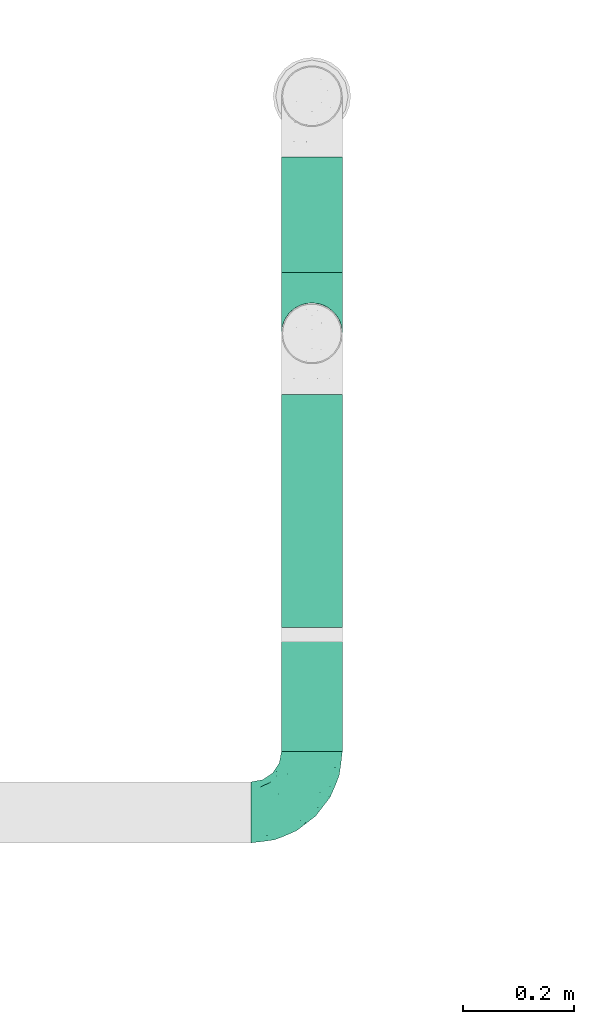
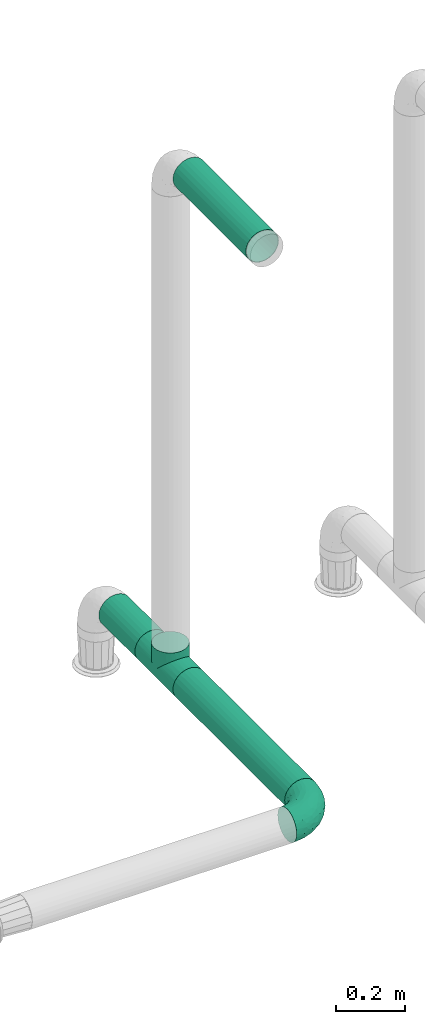
# One storey, part 23 of 103: 3 flow segments, 2 flow fittings.
"""IFC2X3 building model written with IfcOpenShell, lengths in millimetres."""

from ifc_helpers import new_model, entity, si_unit, converted_unit, derived_unit, direction, frame, origin_with_axes, origin_2d_with_axis, place, context, subcontext, project, spatial, hollow_circle, extrude, open_shell, surface_model, source, transform, mapped, material, layer, layer_set, layer_usage, type_object, element, save


model = new_model("IFC2X3")

# Units and contexts
model_context = context("Model", 3, precision=1e-05, world=origin_with_axes(), true_north=direction((0.0, 1.0)))
body_context = subcontext(model_context, "Body", "Model", "MODEL_VIEW")
ifc_project = project(units=[si_unit("AREAUNIT", "SQUARE_METRE"), si_unit("VOLUMEUNIT", "CUBIC_METRE", prefix="DECI"), si_unit("TIMEUNIT", "SECOND"), si_unit("THERMODYNAMICTEMPERATUREUNIT", "DEGREE_CELSIUS"), si_unit("PRESSUREUNIT", "PASCAL"), si_unit("MASSUNIT", "GRAM", prefix="KILO"), si_unit("LENGTHUNIT", "METRE", prefix="MILLI"), si_unit("POWERUNIT", "WATT"), si_unit("ELECTRICCURRENTUNIT", "AMPERE"), si_unit("ELECTRICVOLTAGEUNIT", "VOLT"), derived_unit("VOLUMETRICFLOWRATEUNIT", [(si_unit("VOLUMEUNIT", "CUBIC_METRE", prefix="DECI"), 1), (si_unit("TIMEUNIT", "SECOND"), -1)]), derived_unit("LINEARVELOCITYUNIT", [(si_unit("LENGTHUNIT", "METRE"), 1), (si_unit("TIMEUNIT", "SECOND"), -1)]), derived_unit("MASSDENSITYUNIT", [(si_unit("MASSUNIT", "GRAM", prefix="KILO"), 1), (si_unit("VOLUMEUNIT", "CUBIC_METRE"), -1)]), converted_unit("PLANEANGLEUNIT", "DEGREE", entity("IfcRatioMeasure", 0.01745), si_unit("PLANEANGLEUNIT", "RADIAN"), dimensions=[0, 0, 0, 0, 0, 0, 0])], contexts=[model_context])

# Site, building, storey
site_placement = place(None, origin_with_axes())
site = spatial("IfcSite", under=ifc_project, at=site_placement, CompositionType="ELEMENT")
building_placement = place(site_placement, origin_with_axes())
building = spatial("IfcBuilding", under=site, at=building_placement, Name="mc-building", CompositionType="ELEMENT")
storey_placement = place(building_placement, frame((0.0, 0.0, 5900.0), z_axis=(0.0, 0.0, 1.0), x_axis=(1.0, 0.0, 0.0)))
storey = spatial("IfcBuildingStorey", under=building, at=storey_placement, Name="3. Korrus", CompositionType="ELEMENT", Elevation=5900.0)

# Flow fittings
duct_fitting_type_1 = type_object("IfcDuctFittingType", PredefinedType="JUNCTION")
shared_shape_1 = source(origin_with_axes(), body_context, "Body", "SurfaceModel", [
    surface_model("IfcShellBasedSurfaceModel", [(0.0, -80.0, -55.0), (14.23505, -80.0, -53.12592), (-14.23505, -80.0, -53.12592), (-53.12592, -80.0, 14.23505), (-27.5, -80.0, -47.63139), (-47.63139, -80.0, -27.5), (-38.89087, -80.0, -38.89087), (55.0, -80.0, 0.0), (53.12592, -80.0, 14.23505), (38.89087, -80.0, -38.89087), (27.5, -80.0, -47.63139), (53.12592, -80.0, -14.23505), (47.63139, -80.0, -27.5), (-53.12592, -80.0, -14.23505), (-47.63139, -80.0, 27.5), (-38.89087, -80.0, 38.89087), (14.23505, -80.0, 53.12592), (-27.5, -80.0, 47.63139), (-14.23505, -80.0, 53.12592), (47.63139, -80.0, 27.5), (38.89087, -80.0, 38.89087), (27.5, -80.0, 47.63139), (0.0, -80.0, 55.0), (-55.0, -80.0, 0.0), (0.0, 0.0, 55.0), (-7.4066, -7.4066, 54.49901), (-14.74521, -14.74521, 52.98659), (-21.93978, -21.93978, 50.43457), (-28.89905, -28.89905, 46.79578), (-35.50357, -35.50357, 42.00591), (-41.58668, -41.58668, 35.99373), (-46.92319, -46.92319, 28.69171), (-51.19777, -51.19777, 20.0945), (-50.37866, -80.0, 20.86752), (-54.01174, -54.01174, 10.37938), (-55.0, -55.0, 0.0), (-54.06296, -80.0, 7.11752), (-54.01174, -54.01174, -10.37938), (-51.19777, -51.19777, -20.0945), (-54.06296, -80.0, -7.11752), (-46.92319, -46.92319, -28.69171), (-41.58668, -41.58668, -35.99373), (-50.37866, -80.0, -20.86752), (-35.50357, -35.50357, -42.00591), (-21.93978, -21.93978, -50.43457), (-14.74521, -14.74521, -52.98659), (-7.4066, -7.4066, -54.49901), (0.0, 0.0, -55.0), (-28.89905, -28.89905, -46.79578), (7.4066, -7.4066, -54.49901), (14.74521, -14.74521, -52.98659), (21.93978, -21.93978, -50.43457), (28.89905, -28.89905, -46.79578), (35.50357, -35.50357, -42.00591), (41.58668, -41.58668, -35.99373), (46.92319, -46.92319, -28.69171), (51.19777, -51.19777, -20.0945), (50.37866, -80.0, -20.86752), (54.01174, -54.01174, -10.37938), (55.0, -55.0, 0.0), (54.06296, -80.0, -7.11752), (54.01174, -54.01174, 10.37938), (51.19777, -51.19777, 20.0945), (54.06296, -80.0, 7.11752), (46.92319, -46.92319, 28.69171), (41.58668, -41.58668, 35.99373), (50.37866, -80.0, 20.86752), (35.50357, -35.50357, 42.00591), (21.93978, -21.93978, 50.43457), (14.74521, -14.74521, 52.98659), (7.4066, -7.4066, 54.49901), (28.89905, -28.89905, 46.79578), (-110.0, 0.0, -55.0), (-110.0, -14.23505, -53.12592), (-110.0, 14.23505, -53.12592), (-110.0, 53.12592, 14.23505), (-110.0, 27.5, -47.63139), (-110.0, 47.63139, -27.5), (-110.0, 38.89087, -38.89087), (-110.0, -55.0, 0.0), (-110.0, -53.12592, 14.23505), (-110.0, -38.89087, -38.89087), (-110.0, -27.5, -47.63139), (-110.0, -53.12592, -14.23505), (-110.0, -47.63139, -27.5), (-110.0, 53.12592, -14.23505), (-110.0, 47.63139, 27.5), (-110.0, 38.89087, 38.89087), (-110.0, -14.23505, 53.12592), (-110.0, 27.5, 47.63139), (-110.0, 14.23505, 53.12592), (-110.0, -47.63139, 27.5), (-110.0, -38.89087, 38.89087), (-110.0, -27.5, 47.63139), (-110.0, 0.0, 55.0), (-110.0, 55.0, 0.0), (110.0, 55.0, 0.0), (110.0, 0.0, -55.0), (110.0, 14.23505, -53.12592), (110.0, 27.5, -47.63139), (110.0, 38.89087, -38.89087), (110.0, 47.63139, -27.5), (110.0, -38.89087, -38.89087), (110.0, -53.12592, 14.23505), (110.0, -27.5, -47.63139), (110.0, -14.23505, -53.12592), (110.0, -47.63139, -27.5), (110.0, -53.12592, -14.23505), (110.0, -55.0, 0.0), (110.0, 53.12592, -14.23505), (110.0, 53.12592, 14.23505), (110.0, 47.63139, 27.5), (110.0, 38.89087, 38.89087), (110.0, 0.0, 55.0), (110.0, 27.5, 47.63139), (110.0, 14.23505, 53.12592), (110.0, -47.63139, 27.5), (110.0, -38.89087, 38.89087), (110.0, -27.5, 47.63139), (110.0, -14.23505, 53.12592)], [open_shell([[[0, 1, 2]], [[2, 3, 4]], [[5, 6, 3]], [[6, 4, 3]], [[2, 7, 8]], [[9, 7, 10]], [[1, 10, 7]], [[11, 7, 12]], [[9, 12, 7]], [[7, 2, 1]], [[5, 3, 13]], [[2, 14, 3]], [[2, 15, 14]], [[2, 16, 17]], [[17, 15, 2]], [[16, 18, 17]], [[2, 8, 19]], [[2, 19, 20]], [[2, 20, 21]], [[16, 2, 21]], [[16, 22, 18]], [[23, 13, 3]], [[24, 25, 22]], [[26, 27, 18]], [[25, 26, 18]], [[22, 25, 18]], [[17, 28, 29]], [[17, 18, 27]], [[17, 29, 15]], [[28, 17, 27]], [[30, 31, 14]], [[32, 3, 33]], [[32, 34, 3]], [[35, 36, 34]], [[31, 32, 14]], [[15, 30, 14]], [[34, 36, 3]], [[33, 14, 32]], [[36, 35, 23]], [[30, 15, 29]], [[37, 38, 13]], [[37, 13, 39]], [[40, 41, 5]], [[38, 5, 42]], [[38, 40, 5]], [[37, 39, 35]], [[35, 39, 23]], [[13, 38, 42]], [[41, 6, 5]], [[41, 43, 6]], [[44, 45, 2]], [[46, 47, 0]], [[45, 46, 2]], [[43, 48, 4]], [[44, 4, 48]], [[44, 2, 4]], [[46, 0, 2]], [[43, 4, 6]], [[47, 49, 0]], [[50, 51, 1]], [[49, 50, 1]], [[0, 49, 1]], [[10, 52, 53]], [[10, 1, 51]], [[10, 53, 9]], [[52, 10, 51]], [[54, 55, 12]], [[56, 11, 57]], [[56, 58, 11]], [[59, 60, 58]], [[55, 56, 12]], [[9, 54, 12]], [[58, 60, 11]], [[57, 12, 56]], [[60, 59, 7]], [[54, 9, 53]], [[61, 62, 8]], [[61, 8, 63]], [[64, 65, 19]], [[62, 19, 66]], [[62, 64, 19]], [[61, 63, 59]], [[7, 59, 63]], [[62, 66, 8]], [[65, 20, 19]], [[65, 67, 20]], [[68, 69, 16]], [[70, 24, 22]], [[69, 70, 16]], [[67, 71, 21]], [[68, 21, 71]], [[68, 16, 21]], [[70, 22, 16]], [[67, 21, 20]], [[72, 73, 74]], [[74, 75, 76]], [[77, 78, 75]], [[76, 75, 78]], [[74, 79, 80]], [[81, 79, 82]], [[73, 82, 79]], [[83, 79, 84]], [[81, 84, 79]], [[79, 74, 73]], [[77, 75, 85]], [[74, 86, 75]], [[74, 87, 86]], [[74, 88, 89]], [[89, 87, 74]], [[88, 90, 89]], [[74, 91, 92]], [[91, 74, 80]], [[92, 93, 74]], [[74, 93, 88]], [[88, 94, 90]], [[95, 85, 75]], [[96, 97, 98]], [[99, 96, 98]], [[96, 100, 101]], [[100, 96, 99]], [[102, 97, 103]], [[97, 102, 104]], [[104, 105, 97]], [[102, 103, 106]], [[106, 103, 107]], [[108, 107, 103]], [[109, 96, 101]], [[110, 111, 97]], [[97, 111, 112]], [[113, 97, 114]], [[97, 112, 114]], [[113, 114, 115]], [[116, 103, 97]], [[117, 116, 97]], [[118, 117, 97]], [[119, 118, 97]], [[119, 97, 113]], [[96, 110, 97]], [[24, 113, 115]], [[89, 115, 114]], [[94, 24, 90]], [[90, 24, 115]], [[115, 89, 90]], [[114, 87, 89]], [[86, 112, 111]], [[75, 111, 110]], [[95, 110, 96]], [[87, 112, 86]], [[86, 111, 75]], [[110, 95, 75]], [[112, 87, 114]], [[85, 96, 109]], [[77, 109, 101]], [[95, 96, 85]], [[85, 109, 77]], [[101, 78, 77]], [[101, 100, 78]], [[76, 100, 99]], [[74, 99, 98]], [[47, 98, 97]], [[76, 99, 74]], [[47, 72, 74]], [[98, 47, 74]], [[100, 76, 78]], [[47, 46, 72]], [[45, 44, 73]], [[46, 45, 73]], [[72, 46, 73]], [[82, 48, 43]], [[82, 73, 44]], [[82, 43, 81]], [[48, 82, 44]], [[41, 40, 84]], [[38, 37, 83]], [[40, 38, 84]], [[81, 41, 84]], [[37, 79, 83]], [[83, 84, 38]], [[79, 37, 35]], [[41, 81, 43]], [[49, 97, 105]], [[105, 104, 51]], [[53, 104, 102]], [[53, 52, 104]], [[49, 47, 97]], [[51, 50, 105]], [[52, 51, 104]], [[49, 105, 50]], [[54, 102, 106]], [[56, 106, 107]], [[58, 107, 108]], [[55, 54, 106]], [[58, 56, 107]], [[59, 58, 108]], [[55, 106, 56]], [[102, 54, 53]], [[34, 32, 80]], [[31, 30, 91]], [[32, 31, 91]], [[35, 34, 79]], [[80, 79, 34]], [[32, 91, 80]], [[30, 92, 91]], [[30, 29, 92]], [[27, 26, 88]], [[25, 24, 94]], [[26, 25, 88]], [[29, 28, 93]], [[27, 93, 28]], [[27, 88, 93]], [[25, 94, 88]], [[29, 93, 92]], [[61, 108, 103]], [[62, 103, 116]], [[65, 116, 117]], [[61, 59, 108]], [[64, 62, 116]], [[65, 64, 116]], [[61, 103, 62]], [[117, 67, 65]], [[71, 67, 118]], [[118, 67, 117]], [[68, 118, 119]], [[70, 119, 113]], [[68, 71, 118]], [[70, 69, 119]], [[24, 70, 113]], [[68, 119, 69]]])]),
])
flow_fitting_1_placement = place(storey_placement, frame((15585.80789, 4302.28735, 2345.0), z_axis=(-1.0, 0.0, 0.0), x_axis=(0.0, 1.0, 0.0)))
element("IfcFlowFitting", 1, at=flow_fitting_1_placement, inside=storey, type_object=duct_fitting_type_1, context=body_context, shape_type="MappedRepresentation", body=[
    mapped(shared_shape_1, transform((0.0, 0.0, 0.0), scale=1.0)),
])
duct_fitting_type_2 = type_object("IfcDuctFittingType", Name="BU", PredefinedType="BEND")
shared_shape_2 = source(origin_with_axes(), body_context, "Body", "SurfaceModel", [
    surface_model("IfcShellBasedSurfaceModel", [(-110.0, 0.0, -55.0), (-110.0, -14.23505, -53.12592), (-110.0, 14.23505, -53.12592), (-110.0, 53.12592, 14.23505), (-110.0, 27.5, -47.63139), (-110.0, 38.89087, -38.89087), (-110.0, -55.0, 0.0), (-110.0, -53.12592, 14.23505), (-110.0, -38.89087, -38.89087), (-110.0, -27.5, -47.63139), (-110.0, -53.12592, -14.23505), (-110.0, -47.63139, -27.5), (-110.0, -14.23505, 53.12592), (-110.0, 14.23505, 53.12592), (-110.0, 27.5, 47.63139), (-110.0, -47.63139, 27.5), (-110.0, -38.89087, 38.89087), (-110.0, -27.5, 47.63139), (-110.0, 0.0, 55.0), (-110.0, 55.0, 0.0), (-110.0, 53.12592, -14.23505), (-110.0, 47.63139, -27.5), (-110.0, 47.63139, 27.5), (-110.0, 38.89087, 38.89087), (-14.23505, 110.0, -53.12592), (-55.0, 110.0, 0.0), (0.0, 110.0, -55.0), (-27.5, 110.0, -47.63139), (-38.89087, 110.0, -38.89087), (-47.63139, 110.0, -27.5), (38.89087, 110.0, -38.89087), (53.12592, 110.0, 14.23505), (27.5, 110.0, -47.63139), (14.23505, 110.0, -53.12592), (47.63139, 110.0, -27.5), (53.12592, 110.0, -14.23505), (55.0, 110.0, 0.0), (-53.12592, 110.0, -14.23505), (-53.12592, 110.0, 14.23505), (-47.63139, 110.0, 27.5), (-38.89087, 110.0, 38.89087), (-27.5, 110.0, 47.63139), (0.0, 110.0, 55.0), (-14.23505, 110.0, 53.12592), (38.89087, 110.0, 38.89087), (47.63139, 110.0, 27.5), (27.5, 110.0, 47.63139), (14.23505, 110.0, 53.12592), (-64.21732, 48.68956, 43.63444), (-76.6405, 38.18013, 45.55988), (-60.44912, 32.56953, 51.94617), (-76.00813, 5.38378, 55.0), (-90.15553, 11.94394, 54.09138), (-78.5998, 26.77405, 50.81338), (-70.18771, 18.55163, 54.03432), (-75.55424, 54.2118, 32.41257), (-93.27622, 45.77614, 33.48188), (-96.12334, 22.13664, 50.81337), (-21.00813, 45.34362, 55.0), (-18.36258, 70.48427, 54.04484), (-32.04182, 59.64019, 52.24446), (-63.88653, 74.77858, 17.99134), (-74.66383, 63.08407, 19.92123), (-63.60674, 66.07878, 29.97482), (-99.597, 52.72185, 18.52927), (-93.11138, 56.59448, 10.50359), (-98.21577, 57.34403, 0.0), (-53.42855, 92.60092, 21.04759), (-88.54852, 54.8376, 21.04759), (-11.86161, 90.23965, 54.10313), (-5.38378, 76.00813, 55.0), (-57.34403, 98.21577, 0.0), (-56.64619, 93.12774, 10.22088), (-45.34362, 21.00813, 55.0), (-44.60838, 44.60838, 52.13415), (-92.68484, 35.46673, 43.63443), (-22.25266, 95.40765, 50.81337), (-35.97783, 90.61597, 43.63443), (-43.70931, 69.58671, 44.47149), (-27.23711, 77.39884, 50.81337), (-57.2828, 79.3123, 24.9774), (-58.67786, 84.31125, 16.04456), (-82.93277, 60.36161, 12.91784), (-49.88337, 54.51816, 47.224), (-74.57753, 66.83759, 9.55742), (-45.35812, 94.97281, 33.48188), (-59.18663, 88.95241, 0.0), (-51.517, 78.6292, 33.48188), (-65.14788, 80.03077, 0.0), (-56.45322, 62.06476, 39.63545), (-88.95241, 59.18663, 0.0), (-71.10913, 71.10913, 0.0), (-80.03077, 65.14788, 0.0), (-94.9309, 45.36788, -33.48188), (-93.11358, 56.60141, -10.46614), (-99.64997, 52.79499, -18.30015), (-90.20425, 36.08686, -43.63443), (-79.99933, 46.56772, -37.92748), (-76.00813, 5.38378, -55.0), (-72.75364, 19.68651, -53.60527), (-45.34362, 21.00813, -55.0), (-21.91957, 65.12078, -53.85897), (-5.38378, 76.00813, -55.0), (-21.00813, 45.34362, -55.0), (-35.41876, 92.89265, -43.63443), (-91.10309, 11.02766, -54.21832), (-45.77614, 93.27622, -33.48188), (-90.50474, 23.21022, -50.81337), (-70.92854, 33.31794, -49.51754), (-78.52933, 63.35627, -11.73997), (-24.91508, 84.05606, -50.81337), (-88.78941, 54.74452, -21.04759), (-69.59921, 57.34866, -33.48187), (-73.36422, 62.46673, -22.94182), (-63.49062, 67.59111, -28.46929), (-56.59448, 93.11138, -10.50359), (-54.8376, 88.54852, -21.04759), (-54.10679, 75.85581, -32.31867), (-57.75956, 31.09612, -52.80882), (-52.72185, 99.597, -18.52927), (-12.62913, 89.46304, -53.99097), (-34.46825, 66.46123, -50.04329), (-43.9837, 43.9837, -52.42279), (-65.78527, 72.58348, -17.68796), (-70.34468, 43.65295, -44.21951), (-57.47001, 51.99467, -44.91465), (-60.72547, 82.29174, -12.88567), (-42.34915, 74.24548, -43.63444), (-57.25194, 63.5016, -38.08211), (-80.95344, 53.56991, -29.32027), (-52.32891, 4.55257, -54.0482), (32.52942, 47.13398, -30.48571), (14.88266, 20.92917, -33.7947), (14.95561, 36.05775, -42.26543), (30.24048, 70.09027, -41.7461), (19.3559, 65.35825, -48.00507), (-70.35075, -46.44478, -19.5952), (-47.13398, -32.52942, -30.48571), (-28.49299, -30.5778, -16.4009), (-4.55257, 52.32891, -54.0482), (-22.4954, 22.4954, -53.25347), (-75.47368, -11.22546, -52.60718), (-81.32209, -51.5606, -9.98467), (-80.81763, -41.84862, -32.14655), (-70.09027, -30.24048, -41.7461), (-36.05774, -14.95561, -42.26543), (-9.15831, -10.852, -27.8997), (-65.35825, -19.3559, -48.00507), (11.22546, 75.47368, -52.60718), (3.94376, 43.9333, -50.53315), (-13.39742, 13.39743, -48.13058), (-43.9333, -3.94376, -50.53315), (49.37776, 67.29486, 0.0), (41.8609, 47.82256, -9.92641), (50.20582, 74.51695, -9.9731), (18.93131, 11.7156, -17.56239), (-27.5, -32.89419, 0.0), (-1.23348, -12.25375, -12.18106), (41.84862, 80.81763, -32.14655), (35.70604, 41.31408, -20.38235), (46.44478, 70.35075, -19.5952), (32.89419, 27.5, 0.0), (6.67262, -6.67262, 0.0), (-67.29486, -49.37776, 0.0), (-50.36265, -42.95545, -9.51562), (-5.47251, 5.47251, -39.92906), (-70.35075, -46.44478, 19.5952), (-74.51695, -50.20582, 9.9731), (-41.31407, -35.70604, 20.38235), (-47.13398, -32.52942, 30.48571), (-80.81763, -41.84862, 32.14655), (-4.55257, 52.32891, 54.0482), (11.22546, 75.47368, 52.60718), (-43.9333, -3.94376, 50.53315), (-65.35825, -19.3559, 48.00507), (-36.05774, -14.95561, 42.26543), (-70.09027, -30.24048, 41.7461), (-11.7156, -18.93131, 17.56239), (30.5778, 28.49299, 16.4009), (12.25375, 1.23348, 12.18106), (51.5606, 81.32209, 9.98467), (42.95545, 50.36265, 9.51562), (-75.47368, -11.22546, 52.60718), (-52.32891, 4.55257, 54.0482), (3.94376, 43.9333, 50.53315), (-22.4954, 22.4954, 53.25347), (-13.39742, 13.39743, 48.13058), (10.852, 9.15831, 27.8997), (-20.92916, -14.88266, 33.79469), (-47.82256, -41.8609, 9.92641), (32.52942, 47.13398, 30.48571), (46.44478, 70.35075, 19.5952), (41.84862, 80.81763, 32.14655), (30.24048, 70.09027, 41.7461), (19.3559, 65.35825, 48.00507), (14.95561, 36.05775, 42.26543), (-5.47251, 5.47251, 39.92906)], [open_shell([[[0, 1, 2]], [[2, 3, 4]], [[4, 3, 5]], [[2, 6, 7]], [[8, 6, 9]], [[1, 9, 6]], [[10, 6, 11]], [[8, 11, 6]], [[6, 2, 1]], [[12, 13, 14]], [[15, 2, 7]], [[16, 17, 2]], [[2, 17, 12]], [[12, 18, 13]], [[19, 20, 3]], [[5, 3, 21]], [[20, 21, 3]], [[22, 3, 2]], [[23, 22, 2]], [[12, 14, 2]], [[2, 14, 23]], [[15, 16, 2]], [[24, 25, 26]], [[27, 25, 24]], [[25, 28, 29]], [[28, 25, 27]], [[30, 26, 31]], [[26, 30, 32]], [[32, 33, 26]], [[34, 31, 35]], [[31, 34, 30]], [[35, 31, 36]], [[29, 37, 25]], [[38, 39, 26]], [[39, 40, 26]], [[41, 42, 40]], [[42, 26, 40]], [[42, 41, 43]], [[26, 44, 45]], [[31, 26, 45]], [[26, 46, 44]], [[47, 46, 26]], [[42, 47, 26]], [[25, 38, 26]], [[48, 49, 50]], [[18, 51, 52]], [[53, 54, 50]], [[55, 56, 49]], [[56, 22, 23]], [[13, 57, 14]], [[58, 59, 60]], [[61, 62, 63]], [[3, 64, 65]], [[53, 52, 54]], [[3, 65, 66]], [[67, 39, 38]], [[56, 68, 64]], [[65, 64, 68]], [[69, 59, 70]], [[38, 71, 72]], [[73, 58, 74]], [[75, 49, 56]], [[76, 69, 43]], [[53, 57, 52]], [[77, 78, 79]], [[41, 76, 43]], [[43, 69, 42]], [[55, 68, 56]], [[23, 14, 75]], [[76, 77, 79]], [[80, 67, 81]], [[62, 82, 68]], [[60, 78, 83]], [[62, 84, 82]], [[85, 77, 40]], [[81, 67, 72]], [[86, 72, 71]], [[87, 85, 67]], [[61, 81, 88]], [[77, 41, 40]], [[78, 77, 87]], [[23, 75, 56]], [[83, 89, 48]], [[85, 40, 39]], [[62, 68, 55]], [[89, 87, 63]], [[83, 48, 50]], [[57, 75, 14]], [[49, 75, 53]], [[67, 85, 39]], [[87, 77, 85]], [[63, 62, 55]], [[89, 55, 48]], [[80, 63, 87]], [[66, 65, 90]], [[66, 19, 3]], [[84, 91, 92]], [[92, 90, 82]], [[65, 82, 90]], [[61, 84, 62]], [[92, 82, 84]], [[68, 82, 65]], [[3, 22, 64]], [[56, 64, 22]], [[38, 25, 71]], [[81, 72, 86]], [[38, 72, 67]], [[91, 61, 88]], [[80, 81, 61]], [[63, 80, 61]], [[67, 80, 87]], [[77, 76, 41]], [[79, 59, 69]], [[79, 69, 76]], [[42, 69, 70]], [[60, 59, 79]], [[58, 70, 59]], [[78, 60, 79]], [[58, 60, 74]], [[52, 57, 13]], [[75, 57, 53]], [[18, 52, 13]], [[52, 51, 54]], [[51, 73, 54]], [[50, 73, 74]], [[73, 50, 54]], [[50, 74, 83]], [[60, 83, 74]], [[89, 83, 78]], [[87, 89, 78]], [[55, 89, 63]], [[50, 49, 53]], [[55, 49, 48]], [[81, 86, 88]], [[91, 84, 61]], [[5, 21, 93]], [[90, 94, 66]], [[20, 94, 95]], [[96, 93, 97]], [[98, 99, 100]], [[96, 4, 5]], [[101, 102, 103]], [[28, 27, 104]], [[2, 105, 0]], [[104, 106, 28]], [[99, 105, 107]], [[108, 107, 96]], [[90, 109, 94]], [[107, 2, 4]], [[20, 66, 94]], [[27, 24, 110]], [[109, 111, 94]], [[112, 113, 114]], [[37, 115, 71]], [[116, 106, 117]], [[99, 118, 100]], [[116, 115, 119]], [[37, 119, 115]], [[24, 120, 110]], [[121, 110, 101]], [[119, 106, 116]], [[101, 110, 120]], [[122, 103, 100]], [[117, 123, 116]], [[124, 125, 108]], [[115, 116, 126]], [[106, 29, 28]], [[26, 102, 120]], [[127, 104, 110]], [[97, 124, 96]], [[125, 122, 118]], [[128, 127, 125]], [[96, 5, 93]], [[115, 126, 86]], [[117, 106, 127]], [[111, 113, 129]], [[95, 93, 21]], [[97, 129, 112]], [[110, 104, 27]], [[106, 104, 127]], [[96, 107, 4]], [[99, 107, 108]], [[99, 108, 118]], [[105, 99, 98]], [[112, 114, 128]], [[121, 125, 127]], [[20, 19, 66]], [[109, 90, 92]], [[94, 111, 95]], [[91, 123, 109]], [[129, 113, 112]], [[93, 95, 111]], [[21, 20, 95]], [[71, 115, 86]], [[71, 25, 37]], [[123, 91, 88]], [[126, 116, 123]], [[123, 88, 126]], [[86, 126, 88]], [[37, 29, 119]], [[106, 119, 29]], [[129, 93, 111]], [[124, 112, 125]], [[0, 105, 98]], [[107, 105, 2]], [[125, 118, 108]], [[100, 118, 122]], [[93, 129, 97]], [[113, 111, 109]], [[109, 123, 113]], [[114, 123, 117]], [[123, 114, 113]], [[128, 114, 117]], [[127, 128, 117]], [[112, 128, 125]], [[103, 122, 101]], [[110, 121, 127]], [[101, 122, 121]], [[125, 121, 122]], [[26, 120, 24]], [[101, 120, 102]], [[96, 124, 108]], [[92, 91, 109]], [[112, 124, 97]], [[100, 130, 98]], [[131, 132, 133]], [[32, 134, 135]], [[136, 137, 138]], [[139, 140, 103]], [[98, 141, 0]], [[142, 10, 136]], [[143, 144, 137]], [[6, 10, 142]], [[137, 145, 146]], [[144, 147, 145]], [[143, 136, 11]], [[11, 136, 10]], [[8, 143, 11]], [[148, 149, 139]], [[8, 9, 144]], [[9, 1, 147]], [[130, 141, 98]], [[103, 140, 100]], [[148, 135, 149]], [[150, 151, 140]], [[152, 153, 154]], [[130, 140, 151]], [[148, 26, 33]], [[147, 1, 141]], [[155, 146, 132]], [[156, 138, 157]], [[134, 30, 158]], [[150, 140, 149]], [[158, 30, 34]], [[30, 134, 32]], [[153, 159, 160]], [[131, 160, 159]], [[144, 145, 137]], [[36, 152, 154]], [[146, 138, 137]], [[155, 161, 162]], [[158, 160, 131]], [[133, 149, 135]], [[156, 163, 164]], [[163, 142, 164]], [[139, 103, 102]], [[153, 152, 161]], [[34, 35, 160]], [[162, 157, 155]], [[132, 165, 133]], [[157, 146, 155]], [[140, 130, 100]], [[141, 130, 151]], [[141, 151, 147]], [[141, 1, 0]], [[102, 26, 148]], [[140, 139, 149]], [[102, 148, 139]], [[135, 33, 32]], [[151, 150, 145]], [[9, 147, 144]], [[151, 145, 147]], [[145, 165, 146]], [[135, 148, 33]], [[133, 135, 134]], [[131, 133, 134]], [[133, 165, 150]], [[133, 150, 149]], [[145, 150, 165]], [[132, 131, 159]], [[146, 165, 132]], [[160, 158, 34]], [[134, 158, 131]], [[144, 143, 8]], [[136, 143, 137]], [[155, 153, 161]], [[154, 153, 160]], [[153, 155, 159]], [[132, 159, 155]], [[160, 35, 154]], [[36, 154, 35]], [[164, 136, 138]], [[6, 142, 163]], [[136, 164, 142]], [[156, 164, 138]], [[156, 157, 162]], [[146, 157, 138]], [[15, 7, 166]], [[6, 163, 167]], [[168, 169, 166]], [[166, 169, 170]], [[171, 172, 70]], [[173, 174, 175]], [[17, 176, 174]], [[177, 156, 162]], [[176, 16, 170]], [[170, 16, 15]], [[161, 178, 179]], [[152, 180, 181]], [[182, 173, 183]], [[18, 12, 182]], [[184, 185, 186]], [[183, 185, 73]], [[183, 73, 51]], [[177, 187, 188]], [[189, 168, 166]], [[187, 178, 190]], [[16, 176, 17]], [[161, 152, 181]], [[45, 191, 31]], [[45, 44, 192]], [[192, 191, 45]], [[180, 36, 31]], [[193, 194, 195]], [[46, 47, 194]], [[193, 195, 190]], [[193, 44, 46]], [[172, 42, 70]], [[185, 58, 73]], [[189, 163, 156]], [[163, 189, 167]], [[70, 58, 171]], [[184, 171, 185]], [[169, 188, 175]], [[180, 31, 191]], [[192, 193, 190]], [[191, 190, 178]], [[182, 174, 173]], [[194, 47, 172]], [[190, 195, 187]], [[186, 185, 173]], [[162, 179, 177]], [[188, 196, 175]], [[179, 187, 177]], [[185, 171, 58]], [[172, 171, 184]], [[172, 184, 194]], [[172, 47, 42]], [[51, 18, 182]], [[185, 183, 173]], [[51, 182, 183]], [[174, 12, 17]], [[184, 186, 195]], [[46, 194, 193]], [[184, 195, 194]], [[195, 196, 187]], [[174, 182, 12]], [[175, 174, 176]], [[169, 175, 176]], [[175, 196, 186]], [[175, 186, 173]], [[195, 186, 196]], [[188, 169, 168]], [[187, 196, 188]], [[166, 170, 15]], [[176, 170, 169]], [[193, 192, 44]], [[191, 192, 190]], [[177, 189, 156]], [[167, 189, 166]], [[189, 177, 168]], [[188, 168, 177]], [[166, 7, 167]], [[6, 167, 7]], [[181, 191, 178]], [[36, 180, 152]], [[191, 181, 180]], [[161, 181, 178]], [[161, 179, 162]], [[187, 179, 178]]])]),
])
flow_fitting_2_placement = place(storey_placement, frame((15585.80789, 3436.80698, 2345.0), z_axis=(0.0, 0.0, 1.0), x_axis=(1.0, 0.0, 0.0)))
element("IfcFlowFitting", 2, at=flow_fitting_2_placement, inside=storey, type_object=duct_fitting_type_2, Name="BU", context=body_context, shape_type="MappedRepresentation", body=[
    mapped(shared_shape_2, transform((0.0, 0.0, 0.0), scale=1.0)),
])

# Flow segments
ifc_material = material(Name="FZ1")
ifc_layer = layer(ifc_material, 0.0)
ifc_layer_set = layer_set([ifc_layer], Name="FZ1")
ifc_layer_usage = layer_usage(ifc_layer_set, "AXIS1", "POSITIVE", 0.0)
duct_segment_type = type_object("IfcDuctSegmentType", Name="Safe", PredefinedType="RIGIDSEGMENT")
shared_shape_3 = source(origin_with_axes(), body_context, "Body", "SweptSolid", [
    extrude(hollow_circle(Radius=55.0, WallThickness=2.0, at=origin_2d_with_axis()), frame((0.0, 0.0, 0.0), z_axis=(1.0, 0.0, 0.0), x_axis=(0.0, 1.0, 0.0)), (0.0, 0.0, 1.0), 208.6),
])
flow_segment_1_placement = place(storey_placement, frame((15585.80789, 4412.28735, 2345.0), z_axis=(0.0, 0.0, 1.0), x_axis=(0.0, 1.0, 0.0)))
element("IfcFlowSegment", 3, at=flow_segment_1_placement, inside=storey, type_object=duct_segment_type, material=ifc_layer_usage, Name="Safe", context=body_context, shape_type="MappedRepresentation", body=[
    mapped(shared_shape_3, transform((0.0, 0.0, 0.0), scale=1.0)),
])
shared_shape_4 = source(origin_with_axes(), body_context, "Body", "SweptSolid", [
    extrude(hollow_circle(Radius=55.0, WallThickness=2.0, at=origin_2d_with_axis()), frame((0.0, 0.0, 0.0), z_axis=(1.0, 0.0, 0.0), x_axis=(0.0, 1.0, 0.0)), (0.0, 0.0, 1.0), 645.5),
])
flow_segment_2_placement = place(storey_placement, frame((15585.80789, 3546.80698, 2345.0), z_axis=(0.0, 0.0, 1.0), x_axis=(0.0, 1.0, 0.0)))
element("IfcFlowSegment", 4, at=flow_segment_2_placement, inside=storey, type_object=duct_segment_type, material=ifc_layer_usage, Name="Safe", context=body_context, shape_type="MappedRepresentation", body=[
    mapped(shared_shape_4, transform((0.0, 0.0, 0.0), scale=1.0)),
])
shared_shape_5 = source(origin_with_axes(), body_context, "Body", "SweptSolid", [
    extrude(hollow_circle(Radius=55.0, WallThickness=2.0, at=origin_2d_with_axis()), frame((0.0, 0.0, 0.0), z_axis=(1.0, 0.0, 0.0), x_axis=(0.0, 1.0, 0.0)), (0.0, 0.0, 1.0), 421.1),
])
flow_segment_3_placement = place(storey_placement, frame((15585.80789, 3771.20513, 4144.0), z_axis=(0.0, 0.0, 1.0), x_axis=(0.0, 1.0, 0.0)))
element("IfcFlowSegment", 5, at=flow_segment_3_placement, inside=storey, type_object=duct_segment_type, material=ifc_layer_usage, Name="Safe", context=body_context, shape_type="MappedRepresentation", body=[
    mapped(shared_shape_5, transform((0.0, 0.0, 0.0), scale=1.0)),
])

save(model, "model.ifc")
